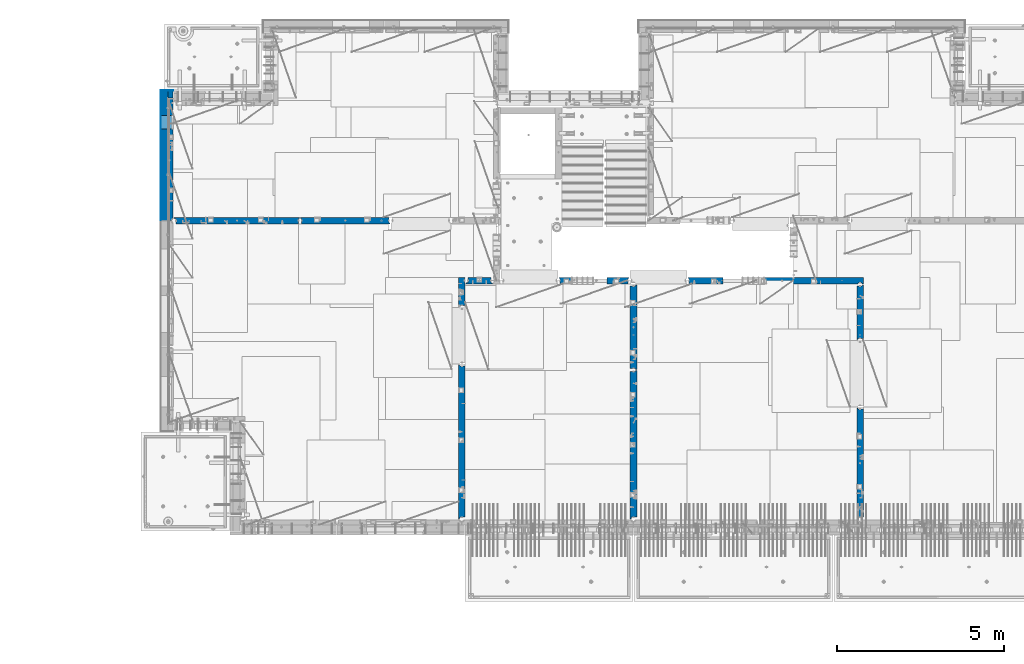
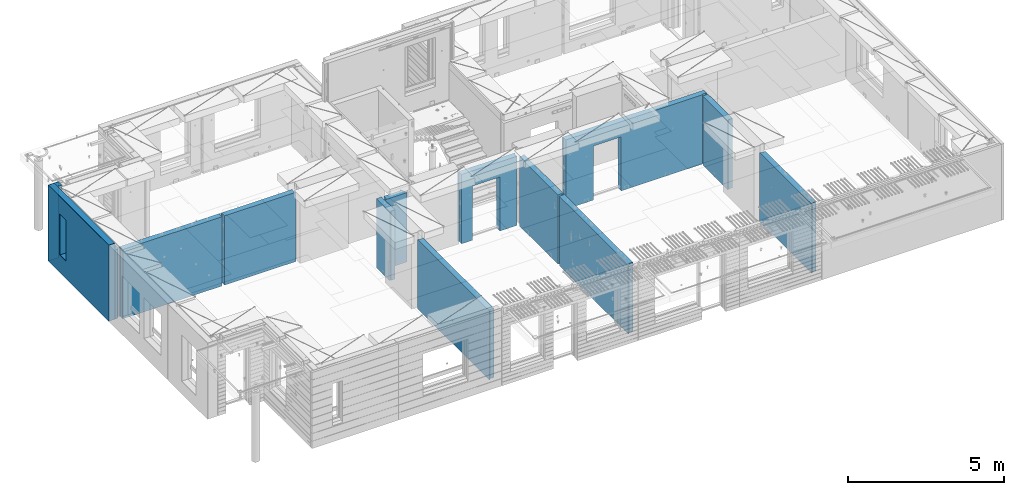
# One storey, part 226 of 341: 16 walls, 12 elements without a shape of their own.
"""IFC2X3 building model written with IfcOpenShell, lengths in millimetres."""

from ifc_helpers import new_model, si_unit, frame, origin_with_axes, place, context, subcontext, project, spatial, faceted_brep, material, type_object, element, aggregate, save


model = new_model("IFC2X3")

# Units and contexts
model_context = context("Model", 3, precision=1e-05, world=origin_with_axes())
body_context = subcontext(model_context, "Body", "Model", "MODEL_VIEW")
ifc_project = project(units=[si_unit("LENGTHUNIT", "METRE", prefix="MILLI"), si_unit("AREAUNIT", "SQUARE_METRE"), si_unit("VOLUMEUNIT", "CUBIC_METRE"), si_unit("MASSUNIT", "GRAM", prefix="KILO"), si_unit("TIMEUNIT", "SECOND"), si_unit("PLANEANGLEUNIT", "RADIAN"), si_unit("SOLIDANGLEUNIT", "STERADIAN"), si_unit("THERMODYNAMICTEMPERATUREUNIT", "DEGREE_CELSIUS"), si_unit("LUMINOUSINTENSITYUNIT", "LUMEN")], contexts=[model_context])

# Site, building, storey
site_placement = place(None, origin_with_axes())
site = spatial("IfcSite", under=ifc_project, at=site_placement, CompositionType="ELEMENT")
building_placement = place(site_placement, origin_with_axes())
building = spatial("IfcBuilding", under=site, at=building_placement, CompositionType="ELEMENT")
storey_placement = place(building_placement, origin_with_axes())
storey = spatial("IfcBuildingStorey", under=building, at=storey_placement, Name="5", CompositionType="ELEMENT", Elevation=0.0)

# Assembly, wall
assembly_1_placement = place(storey_placement, origin_with_axes())
assembly_1 = element("IfcElementAssembly", 1, at=assembly_1_placement, inside=storey, AssemblyPlace="NOTDEFINED", PredefinedType="REINFORCEMENT_UNIT")
ifc_material_1 = material(Name="CONCRETE/C25/30")
wall_type_1 = type_object("IfcWallType", PredefinedType="NOTDEFINED")
wall_1_placement = place(assembly_1_placement, frame((28610.0, 13387.9996249472, 95112.5), z_axis=(0.0, 0.0, 1.0), x_axis=(0.0, 1.0, 0.0)))
wall_1 = element("IfcWall", 2, at=wall_1_placement, type_object=wall_type_1, material=ifc_material_1, context=body_context, shape_type="Brep", body=[
    faceted_brep([(30.9999999999982, 70.0000000000073, 1357.5), (30.9999999999982, 70.0000000000073, -1357.5), (60.9999999999982, 57.0000000000036, -1357.5), (60.9999999999982, 57.0000000000036, 1357.5), (60.9999999999982, -100.0, 1357.5), (60.9999999999982, -100.0, -1357.5), (30.9999999999982, 100.0, -1357.5), (30.9999999999982, 100.0, 1357.5), (1631.00037505278, 100.0, 1357.5), (1631.00037505278, 100.0, -1357.5), (1631.00037505278, -56.9999999999964, 1357.5), (1631.00037505278, -56.9999999999964, -1357.5), (1661.00037505278, -70.0, 1357.5), (1661.00037505278, -70.0, -1357.5), (1661.00037505278, -100.0, 1357.5), (1661.00037505278, -100.0, -1357.5)], [[[0, 1, 2, 3]], [[4, 3, 2, 5]], [[6, 7, 8, 9]], [[10, 11, 9, 8]], [[12, 13, 11, 10]], [[14, 15, 13, 12]], [[15, 14, 4, 5]], [[1, 6, 9, 11, 13, 15, 5, 2]], [[7, 6, 1, 0]], [[14, 12, 10, 8, 7, 0, 3, 4]]]),
])
aggregate(assembly_1, [wall_1])

assembly_2_placement = place(storey_placement, origin_with_axes())
assembly_2 = element("IfcElementAssembly", 3, at=assembly_2_placement, inside=storey, AssemblyPlace="NOTDEFINED", PredefinedType="REINFORCEMENT_UNIT")
wall_2_placement = place(assembly_2_placement, frame((28610.0, 8000.0, 95112.5), z_axis=(0.0, 0.0, 1.0), x_axis=(0.0, 1.0, 0.0)))
wall_2 = element("IfcWall", 4, at=wall_2_placement, type_object=wall_type_1, material=ifc_material_1, context=body_context, shape_type="Brep", body=[
    faceted_brep([(30.0000000000009, 70.0, 1357.5), (30.0, 70.0, -1357.5), (80.0, 57.0, -1357.5), (79.99999955967, 57.0000001052285, 1357.5), (79.9999996695051, -100.0, 1357.5), (80.0, -100.0, -1357.5), (30.0, 100.0, -1357.5), (30.0000000000009, 100.0, 1357.5), (3360.0, 100.0, 1357.5), (3360.0, 100.0, -1357.5), (3360.0, 70.0000000000073, 1357.5), (3360.0, 70.0000000000073, -1357.5), (3330.0, 57.0000000000036, 1357.5), (3330.0, 57.0000000000036, -1357.5), (3330.0, -100.0, 1357.5), (3330.0, -100.0, -1357.5)], [[[0, 1, 2, 3]], [[4, 3, 2, 5]], [[6, 7, 8, 9]], [[9, 8, 10, 11]], [[12, 13, 11, 10]], [[14, 15, 13, 12]], [[15, 14, 4, 5]], [[1, 6, 9, 11, 13, 15, 5, 2]], [[7, 6, 1, 0]], [[14, 12, 10, 8, 7, 0, 3, 4]]]),
])
aggregate(assembly_2, [wall_2])

assembly_3_placement = place(storey_placement, origin_with_axes())
assembly_3 = element("IfcElementAssembly", 5, at=assembly_3_placement, inside=storey, AssemblyPlace="NOTDEFINED", PredefinedType="REINFORCEMENT_UNIT")
wall_3_placement = place(assembly_3_placement, frame((23410.0002919986, 15180.0, 95112.5), z_axis=(0.0, 0.0, 1.0), x_axis=(1.0, 0.0, 0.0)))
wall_3 = element("IfcWall", 6, at=wall_3_placement, type_object=wall_type_1, material=ifc_material_1, context=body_context, shape_type="Brep", body=[
    faceted_brep([(3134.99885559082, 100.0, 762.5), (3147.99885559082, 80.0, 762.5), (3251.99885559082, 80.0, 762.5), (3264.99885559082, 100.0, 762.5), (3147.99885559082, 80.0, 1357.5), (3134.99885559082, 100.0, 1357.5), (3251.99885559082, 80.0, 1357.5), (3264.99885559082, 100.0, 1357.5), (5299.99970800144, -100.0, -1357.5), (5299.99970800144, -100.0, 1357.5), (5264.99970800144, -100.0, 1357.5), (5264.99970800144, -100.0, -1357.5), (5251.99970800144, -70.0, 1357.5), (5251.99970800144, -70.0, -1357.5), (5147.99970800144, -70.0, 1357.5), (5147.99970800144, -70.0, -1357.5), (5134.99970800144, -100.0, 1357.5), (5134.99970800144, -100.0, -1357.5), (59.9988535092562, -100.0, 1357.5), (59.9988535092562, -100.0, -1357.5), (1090.00039464695, -100.0, -1357.5), (1090.00039464695, -100.0, 762.5), (2110.00039464695, -100.0, 762.5), (2110.00039464695, -100.0, -1357.5), (59.9988535092562, 57.0, 1357.5), (59.9988535092562, 57.0, -1357.5), (29.9988535092562, 70.0000000000018, 1357.5), (29.9988535092562, 70.0000000000018, -1357.5), (29.9988535092562, 100.0, 1357.5), (29.9988535092562, 100.0, -1357.5), (1090.00039464695, 100.0, -1357.5), (1090.00039464695, 100.0, 762.5), (2110.00039464695, 100.0, 762.5), (2110.00039464695, 100.0, -1357.5), (5299.99970800144, 100.0, -1357.5), (5299.99970800144, 100.0, 1357.5)], [[[0, 1, 2, 3]], [[4, 1, 0, 5]], [[6, 2, 1, 4]], [[7, 3, 2, 6]], [[8, 9, 10, 11]], [[10, 12, 13, 11]], [[14, 15, 13, 12]], [[16, 17, 15, 14]], [[17, 16, 18, 19, 20, 21, 22, 23]], [[24, 25, 19, 18]], [[26, 27, 25, 24]], [[28, 29, 27, 26]], [[19, 25, 27, 29, 30, 20]], [[31, 21, 20, 30]], [[32, 22, 21, 31]], [[33, 23, 22, 32]], [[34, 8, 11, 13, 15, 17, 23, 33]], [[9, 8, 34, 35]], [[4, 5, 28, 26, 24, 18, 16, 14, 12, 10, 9, 35, 7, 6]], [[35, 34, 33, 32, 31, 30, 29, 28, 5, 0, 3, 7]]]),
])
aggregate(assembly_3, [wall_3])

assembly_4_placement = place(storey_placement, origin_with_axes())
assembly_4 = element("IfcElementAssembly", 7, at=assembly_4_placement, inside=storey, AssemblyPlace="NOTDEFINED", PredefinedType="REINFORCEMENT_UNIT")
wall_4_placement = place(assembly_4_placement, frame((21810.0, 12500.0, 95112.5), z_axis=(0.0, 0.0, 1.0), x_axis=(0.0, 1.0, 0.0)))
wall_4 = element("IfcWall", 8, at=wall_4_placement, type_object=wall_type_1, material=ifc_material_1, context=body_context, shape_type="Brep", body=[
    faceted_brep([(2519.9998239177, -57.0, 1357.5), (2519.9998239177, -57.0, -1357.5), (2519.9998239177, 100.0, -1357.5), (2519.9998239177, 100.0, 1357.5), (2549.9998239177, -70.0, 1357.5), (2549.9998239177, -70.0, -1357.5), (45.0, 100.0, 1357.5), (45.0, 100.0, -1357.5), (45.0, -57.0, -1357.5), (45.0, -57.0, 1357.5), (15.0, -70.0, 1357.5), (15.0, -70.0000000000036, -1357.5), (15.0, -100.0, -1357.5), (15.0, -100.0, 1357.5), (2549.9998239177, -100.0, -1357.5), (2549.9998239177, -100.0, 1357.5)], [[[0, 1, 2, 3]], [[4, 5, 1, 0]], [[6, 7, 8, 9]], [[10, 9, 8, 11]], [[12, 13, 10, 11]], [[13, 12, 14, 15]], [[3, 6, 9, 10, 13, 15, 4, 0]], [[7, 6, 3, 2]], [[14, 12, 11, 8, 7, 2, 1, 5]], [[15, 14, 5, 4]]]),
])
aggregate(assembly_4, [wall_4])

assembly_5_placement = place(storey_placement, origin_with_axes())
assembly_5 = element("IfcElementAssembly", 9, at=assembly_5_placement, inside=storey, AssemblyPlace="NOTDEFINED", PredefinedType="REINFORCEMENT_UNIT")
wall_5_placement = place(assembly_5_placement, frame((21810.0, 8000.0, 95112.5), z_axis=(0.0, 0.0, 1.0), x_axis=(0.0, 1.0, 0.0)))
wall_5 = element("IfcWall", 10, at=wall_5_placement, type_object=wall_type_1, material=ifc_material_1, context=body_context, shape_type="Brep", body=[
    faceted_brep([(30.0000000000009, 70.0, 1357.5), (30.0, 70.0, -1357.5), (80.0, 57.0, -1357.5), (79.99999955967, 57.0000001052285, 1357.5), (79.9999996695051, -100.0, 1357.5), (80.0, -100.0, -1357.5), (30.0, 100.0, -1357.5), (30.0000000000009, 100.0, 1357.5), (4455.0, 100.0, 1357.5), (4455.0, 100.0, -1357.5), (4455.0, -57.0, 1357.5), (4455.0, -57.0, -1357.5), (4485.0, -70.0000000000036, 1357.5), (4485.0, -70.0000000000036, -1357.5), (4485.0, -100.0, 1357.5), (4485.0, -100.0, -1357.5)], [[[0, 1, 2, 3]], [[4, 3, 2, 5]], [[6, 7, 8, 9]], [[10, 11, 9, 8]], [[12, 13, 11, 10]], [[14, 15, 13, 12]], [[15, 14, 4, 5]], [[1, 6, 9, 11, 13, 15, 5, 2]], [[7, 6, 1, 0]], [[14, 12, 10, 8, 7, 0, 3, 4]]]),
])
aggregate(assembly_5, [wall_5])

assembly_6_placement = place(storey_placement, origin_with_axes())
assembly_6 = element("IfcElementAssembly", 11, at=assembly_6_placement, inside=storey, AssemblyPlace="NOTDEFINED", PredefinedType="REINFORCEMENT_UNIT")
wall_6_placement = place(assembly_6_placement, frame((19569.9991455076, 15180.0000000001, 95112.5), z_axis=(0.0, 0.0, 1.0), x_axis=(1.0, 0.0, 0.0)))
wall_6 = element("IfcWall", 12, at=wall_6_placement, type_object=wall_type_1, material=ifc_material_1, context=body_context, shape_type="Brep", body=[
    faceted_brep([(30.0000000001819, 56.9999999999745, 1357.5), (30.0000000001819, 56.9999999999745, -1357.5), (30.0000000001819, -100.0, -1357.5), (30.0000000001819, -100.0, 1357.5), (0.0, 69.9999999999745, 1357.5), (0.0, 69.9999999999745, -1357.5), (1450.00154113788, 100.0, -1357.5), (1450.00154113788, -100.0, -1357.5), (1450.00154113788, -100.0, 762.5), (1450.00154113788, 100.0, 762.5), (430.001541137881, 100.0, 762.5), (430.001541137881, -100.0, 762.5), (430.001541137881, -100.0, -1357.5), (430.001541137881, 100.0, -1357.5), (0.0, 100.0, -1357.5), (0.0, 100.0, 1357.5), (2110.00085449221, 100.0, 1357.5), (2110.00085449221, 100.0, -1357.5), (2110.00085449272, 70.0000000037435, 1357.5), (2110.00085449221, 70.0000000037435, -1357.5), (2080.00085191853, -100.0, -1357.5), (2080.00085558004, 57.0000004585763, -1357.5), (2080.00085558004, 57.0000004585763, 1357.5), (2080.00085191853, -100.0, 1357.5)], [[[0, 1, 2, 3]], [[4, 5, 1, 0]], [[6, 7, 8, 9]], [[10, 11, 12, 13]], [[9, 8, 11, 10]], [[13, 14, 15, 16, 17, 6, 9, 10]], [[17, 16, 18, 19]], [[20, 7, 6, 17, 19, 21]], [[18, 22, 21, 19]], [[23, 20, 21, 22]], [[12, 11, 8, 7, 20, 23, 3, 2]], [[14, 13, 12, 2, 1, 5]], [[15, 14, 5, 4]], [[23, 22, 18, 16, 15, 4, 0, 3]]]),
])
aggregate(assembly_6, [wall_6])

assembly_7_placement = place(storey_placement, origin_with_axes())
assembly_7 = element("IfcElementAssembly", 13, at=assembly_7_placement, inside=storey, AssemblyPlace="NOTDEFINED", PredefinedType="REINFORCEMENT_UNIT")
wall_7_placement = place(assembly_7_placement, frame((16660.0, 8000.0, 95112.5), z_axis=(0.0, 0.0, 1.0), x_axis=(0.0, 1.0, 0.0)))
wall_7 = element("IfcWall", 14, at=wall_7_placement, type_object=wall_type_1, material=ifc_material_1, context=body_context, shape_type="Brep", body=[
    faceted_brep([(30.0000000000009, 70.0, 1357.5), (30.0, 70.0, -1357.5), (80.0, 57.0, -1357.5), (79.99999955967, 57.0000001052285, 1357.5), (79.9999996695051, -100.0, 1357.5), (80.0, -100.0, -1357.5), (30.0, 100.0, -1357.5), (30.0000000000009, 100.0, 1357.5), (4644.99239711402, 100.0, 1357.5), (4644.99239711402, 100.0, -1357.5), (4644.99653549905, 70.0145277302508, 1357.5), (4644.99653549905, 70.0145277302508, -1357.5), (4614.97833252975, 57.001718635147, 1357.5), (4614.97833252975, 57.001718635147, -1357.5), (4615.00000080787, -100.0, 1357.5), (4615.00000080787, -100.0, -1357.5)], [[[0, 1, 2, 3]], [[4, 3, 2, 5]], [[6, 7, 8, 9]], [[9, 8, 10, 11]], [[12, 13, 11, 10]], [[14, 15, 13, 12]], [[15, 14, 4, 5]], [[1, 6, 9, 11, 13, 15, 5, 2]], [[7, 6, 1, 0]], [[14, 12, 10, 8, 7, 0, 3, 4]]]),
])
aggregate(assembly_7, [wall_7])

assembly_8_placement = place(storey_placement, origin_with_axes())
assembly_8 = element("IfcElementAssembly", 15, at=assembly_8_placement, inside=storey, AssemblyPlace="NOTDEFINED", PredefinedType="REINFORCEMENT_UNIT")
wall_8_placement = place(assembly_8_placement, frame((16660.0, 14375.0001284873, 95112.5), z_axis=(0.0, 0.0, 1.0), x_axis=(0.0, 1.0, 0.0)))
wall_8 = element("IfcWall", 16, at=wall_8_placement, type_object=wall_type_1, material=ifc_material_1, context=body_context, shape_type="Brep", body=[
    faceted_brep([(59.9783637637502, 57.008280238686, -607.5), (29.9765698802239, 70.004139724977, -607.5), (29.972430061518, 100.0, -607.5), (84.972430061518, 100.0, -607.5), (84.972430061518, 50.0, -607.5), (59.9793309975266, 50.0, -607.5), (84.972430061518, 50.0, -1357.5), (84.972430061518, 100.0, -1357.5), (59.9793309975285, 50.0, -1357.5), (739.999871512746, -100.0, 1357.5), (752.999871512742, -80.0, 1357.5), (856.999871512742, -80.0, 1357.5), (869.99987151274, -100.0, 1357.5), (904.999871512742, -100.0, 1357.5), (904.999871512742, 100.0, 1357.5), (29.972430061518, 100.0, 1357.5), (29.9765698802239, 70.004139724977, 1357.5), (59.9783637637502, 57.008280238686, 1357.5), (60.0000329474624, -100.0, 1357.5), (739.999871512746, -100.0, -1357.5), (60.0000329474624, -100.0, -1357.5), (752.999871512742, -80.0, -1357.5), (856.999871512742, -80.0, -1357.5), (869.99987151274, -100.0, -1357.5), (904.999871512742, -100.0, -1357.5), (904.999871512742, 100.0, -1357.5)], [[[0, 1, 2, 3, 4, 5]], [[6, 4, 3, 7]], [[8, 5, 4, 6]], [[9, 10, 11, 12, 13, 14, 15, 16, 17, 18]], [[19, 9, 18, 20]], [[9, 19, 21, 10]], [[10, 21, 22, 11]], [[12, 11, 22, 23]], [[24, 13, 12, 23]], [[13, 24, 25, 14]], [[15, 14, 25, 7, 3, 2]], [[16, 15, 2, 1]], [[17, 16, 1, 0]], [[20, 18, 17, 0, 5, 8]], [[25, 24, 23, 22, 21, 19, 20, 8, 6, 7]]]),
])
aggregate(assembly_8, [wall_8])

assembly_9_placement = place(storey_placement, origin_with_axes())
assembly_9 = element("IfcElementAssembly", 17, at=assembly_9_placement, inside=storey, AssemblyPlace="NOTDEFINED", PredefinedType="REINFORCEMENT_UNIT")
wall_9_placement = place(assembly_9_placement, frame((16790.0, 15180.0, 95112.5), z_axis=(0.0, 0.0, 1.0), x_axis=(1.0, 0.0, 0.0)))
wall_9 = element("IfcWall", 18, at=wall_9_placement, type_object=wall_type_1, material=ifc_material_1, context=body_context, shape_type="Brep", body=[
    faceted_brep([(740.0, 100.0, 1357.5), (740.0, -57.0, 1357.5), (740.0, -57.0, -1357.5), (740.0, 100.0, -1357.5), (790.0, -70.0, 1357.5), (790.0, -69.9999999999982, -1357.5), (50.0, 100.0, 1357.5), (50.0, 100.0, -1357.5), (50.0, -48.3299999999999, -1357.5), (50.0, -48.3299999999999, 1357.5), (0.0, -69.996666666666, -1357.5), (0.0, -69.996666666666, 1357.5), (0.0, -100.0, -1357.5), (0.0, -100.0, 1357.5), (790.0, -100.0, -1357.5), (790.0, -100.0, 1357.5)], [[[0, 1, 2, 3]], [[4, 5, 2, 1]], [[6, 7, 8, 9]], [[9, 8, 10, 11]], [[12, 13, 11, 10]], [[13, 12, 14, 15]], [[1, 0, 6, 9, 11, 13, 15, 4]], [[7, 6, 0, 3]], [[14, 12, 10, 8, 7, 3, 2, 5]], [[15, 14, 5, 4]]]),
])
aggregate(assembly_9, [wall_9])

assembly_10_placement = place(storey_placement, origin_with_axes())
assembly_10 = element("IfcElementAssembly", 19, at=assembly_10_placement, inside=storey, AssemblyPlace="NOTDEFINED", PredefinedType="REINFORCEMENT_UNIT")
wall_10_placement = place(assembly_10_placement, frame((11795.0, 16980.0, 95112.5), z_axis=(0.0, 0.0, 1.0), x_axis=(1.0, 0.0, 0.0)))
wall_10 = element("IfcWall", 20, at=wall_10_placement, type_object=wall_type_1, material=ifc_material_1, context=body_context, shape_type="Brep", body=[
    faceted_brep([(2680.0, 100.0, 1357.5), (2680.0, -57.0, 1357.5), (2680.0, -57.0, -1357.50000000001), (2680.0, 100.0, -1357.5), (2705.0, -67.8333333333321, 1357.5), (2705.0, -67.8333333333321, -1357.5), (25.0, 100.0, 1357.5), (25.0, 100.0, -1357.5), (25.0, 70.0000000000036, -1357.5), (25.0, 70.0000000000036, 1357.5), (55.0, 57.0, -1357.5), (55.0, 57.0, 1357.5), (55.0, -100.0, -1357.5), (55.0, -100.0, 1357.5), (2705.0, -100.0, -1357.5), (2705.0, -100.0, 1357.5)], [[[0, 1, 2, 3]], [[4, 5, 2, 1]], [[6, 7, 8, 9]], [[9, 8, 10, 11]], [[11, 10, 12, 13]], [[14, 15, 13, 12]], [[0, 6, 9, 11, 13, 15, 4, 1]], [[7, 6, 0, 3]], [[14, 12, 10, 8, 7, 3, 2, 5]], [[15, 14, 5, 4]]]),
])
aggregate(assembly_10, [wall_10])

assembly_11_placement = place(storey_placement, origin_with_axes())
assembly_11 = element("IfcElementAssembly", 21, at=assembly_11_placement, inside=storey, AssemblyPlace="NOTDEFINED", PredefinedType="REINFORCEMENT_UNIT")
wall_11_placement = place(assembly_11_placement, frame((8000.0, 16980.0, 95112.5), z_axis=(0.0, 0.0, 1.0), x_axis=(1.0, 0.0, 0.0)))
wall_11 = element("IfcWall", 22, at=wall_11_placement, type_object=wall_type_1, material=ifc_material_1, context=body_context, shape_type="Brep", body=[
    faceted_brep([(80.0, 52.0, 1357.5), (80.0, 52.0, -1357.5), (80.0, -100.0, -1357.5), (79.9999996695051, -100.0, 1357.5), (30.0000022791291, 65.0, 1357.5), (30.0000022791291, 65.0, -1357.5), (30.0, 100.0, -1357.5), (30.0000000000009, 100.0, 1357.5), (3790.0, 100.0, 1357.5), (3790.0, 100.0, -1357.5), (3790.0, 70.0000000000036, 1357.5), (3790.0, 70.0000000000036, -1357.5), (3760.0, 57.0, 1357.5), (3760.0, 57.0, -1357.5), (3760.0, -100.0, 1357.5), (3760.0, -100.0, -1357.5)], [[[0, 1, 2, 3]], [[4, 5, 1, 0]], [[6, 7, 8, 9]], [[9, 8, 10, 11]], [[10, 12, 13, 11]], [[14, 15, 13, 12]], [[15, 14, 3, 2]], [[6, 9, 11, 13, 15, 2, 1, 5]], [[7, 6, 5, 4]], [[14, 12, 10, 8, 7, 4, 0, 3]]]),
])
aggregate(assembly_11, [wall_11])

# Assembly, walls
assembly_12_placement = place(storey_placement, origin_with_axes())
assembly_12 = element("IfcElementAssembly", 23, at=assembly_12_placement, inside=storey, AssemblyPlace="NOTDEFINED", PredefinedType="REINFORCEMENT_UNIT")
ifc_material_2 = material()
wall_type_2 = type_object("IfcWallType", PredefinedType="NOTDEFINED")
wall_12_placement = place(assembly_12_placement, frame((7850.0, 20764.9951872276, 95247.5), z_axis=(0.0, 0.0, 1.0), x_axis=(1.0, 0.0, 0.0)))
wall_12 = element("IfcWall", 24, at=wall_12_placement, type_object=wall_type_2, material=ifc_material_2, context=body_context, shape_type="Brep", body=[
    faceted_brep([(0.0, 110.0, -1492.5), (0.0, 110.0, 1492.5), (150.0, 110.0, 1492.5), (150.0, 110.0, -1492.5), (0.0, -110.0, 1492.5), (150.0, -110.0, 1492.5), (0.0, -110.0, -1492.5), (150.0, -110.0, -1492.5)], [[[0, 1, 2, 3]], [[1, 4, 5, 2]], [[4, 6, 7, 5]], [[6, 0, 3, 7]], [[5, 7, 3, 2]], [[6, 4, 1, 0]]]),
])
wall_13_placement = place(assembly_12_placement, frame((7740.0, 16980.0, 95247.5), z_axis=(0.0, 0.0, 1.0), x_axis=(0.0, 1.0, 0.0)))
wall_13 = element("IfcWall", 25, at=wall_13_placement, type_object=wall_type_2, material=ifc_material_2, context=body_context, shape_type="Brep", body=[
    faceted_brep([(5.0, -110.0, 1492.5), (5.0, -110.0, -1492.5), (3894.99518722756, -110.0, -1492.5), (3894.99518722756, -110.0, 1492.5), (2745.00189658477, -110.0, -802.5), (2745.00189658477, -110.0, 807.5), (3155.00189658477, -110.0, 807.5), (3155.00189658477, -110.0, -802.5), (5.0, 110.0, 1492.5), (3894.99518722756, 110.0, 1492.5), (5.0, 110.0, -1492.5), (3894.99518722756, 110.0, -1492.5), (2745.00189658477, 110.0, -802.5), (3155.00189658477, 110.0, -802.5), (3155.00189658477, 110.0, 807.5), (2745.00189658477, 110.0, 807.5)], [[[0, 1, 2, 3], [4, 5, 6, 7]], [[8, 0, 3, 9]], [[1, 0, 8, 10]], [[1, 10, 11, 2]], [[3, 2, 11, 9]], [[10, 8, 9, 11], [12, 13, 14, 15]], [[6, 14, 13, 7]], [[5, 15, 14, 6]], [[4, 12, 15, 5]], [[7, 13, 12, 4]]]),
])
wall_type_3 = type_object("IfcWallType", PredefinedType="NOTDEFINED")
wall_14_placement = place(assembly_12_placement, frame((7925.0, 16980.0, 95112.5), z_axis=(0.0, 0.0, 1.0), x_axis=(0.0, 1.0, 0.0)))
wall_14 = element("IfcWall", 26, at=wall_14_placement, type_object=wall_type_3, material=ifc_material_1, context=body_context, shape_type="Brep", body=[
    faceted_brep([(3155.00189658477, -74.9999998692319, -667.5), (3155.00189658477, 75.0, -667.5), (2745.00189658477, 75.0, -667.5), (2745.00189658477, -74.9999999986567, -667.5), (2745.00189658477, 75.0, 942.5), (2745.00189658477, -75.000000709987, 942.5), (3155.00189658477, 75.0, 942.5), (3155.00189658477, -75.0000005805623, 942.5), (3674.99518722756, -75.0, -1357.5), (3674.99518722756, -75.0, 1357.5), (3564.99519001209, -75.0000022791282, 1357.5), (3564.99519001209, -75.0, -1357.5), (3674.99518722756, 75.0, 1357.5), (5.0, 75.0, 1357.5), (5.0, -15.0000022791291, 1357.5), (65.0, -75.0, 1357.5), (3484.99518722756, -75.0000001199542, 1357.5), (3497.99518763813, -54.9999993903657, 1357.5), (3551.99518754267, -54.9999994175314, 1357.5), (5.0, 75.0, -1357.5), (5.0, -15.0000022791291, -1357.5), (65.0, -75.0, -1357.5), (3484.99518722756, -75.0, -1357.5), (3497.99518763813, -54.9999993903657, -1357.5), (3551.99518754267, -54.9999994175314, -1357.5), (3674.99518722756, 75.0, -1357.5)], [[[0, 1, 2, 3]], [[3, 2, 4, 5]], [[5, 4, 6, 7]], [[7, 6, 1, 0]], [[8, 9, 10, 11]], [[9, 12, 13, 14, 15, 16, 17, 18, 10]], [[13, 19, 20, 14]], [[15, 14, 20, 21]], [[15, 21, 22, 16], [3, 5, 7, 0]], [[16, 22, 23, 17]], [[17, 23, 24, 18]], [[10, 18, 24, 11]], [[23, 22, 21, 20, 19, 25, 8, 11, 24]], [[9, 8, 25, 12]], [[19, 13, 12, 25], [2, 1, 6, 4]]]),
])
ifc_material_3 = material(Name="CONCRETE/C30/37")
wall_type_4 = type_object("IfcWallType", PredefinedType="NOTDEFINED")
wall_15_placement = place(assembly_12_placement, frame((7630.0, 20879.9952125549, 95247.5), z_axis=(0.0, 0.0, 1.0), x_axis=(1.0, 0.0, 0.0)))
wall_15 = element("IfcWall", 27, at=wall_15_placement, type_object=wall_type_4, material=ifc_material_3, context=body_context, shape_type="Brep", body=[
    faceted_brep([(0.0, 5.0, -1492.5), (0.0, 5.0, 1492.5), (370.0, 5.0, 1492.5), (370.0, 5.0, -1492.5), (0.0, -5.0, 1492.5), (370.0, -5.0, 1492.5), (0.0, -5.0, -1492.5), (370.0, -5.0, -1492.5)], [[[0, 1, 2, 3]], [[1, 4, 5, 2]], [[4, 6, 7, 5]], [[6, 0, 3, 7]], [[5, 7, 3, 2]], [[6, 4, 1, 0]]]),
])
wall_16_placement = place(assembly_12_placement, frame((7625.0, 16980.0, 95247.5), z_axis=(0.0, 0.0, 1.0), x_axis=(0.0, 1.0, 0.0)))
wall_16 = element("IfcWall", 28, at=wall_16_placement, type_object=wall_type_4, material=ifc_material_3, context=body_context, shape_type="Brep", body=[
    faceted_brep([(5.0, -5.0, 1492.5), (5.0, -5.0, -1492.5), (3904.99518722756, -5.0, -1492.5), (3904.99518722756, -5.0, 1492.5), (2745.00189658477, -5.0, -802.5), (2745.00189658477, -5.0, 807.5), (3155.00189658477, -5.0, 807.5), (3155.00189658477, -5.0, -802.5), (5.0, 5.0, 1492.5), (3904.99518722756, 5.0, 1492.5), (5.0, 5.0, -1492.5), (3904.99518722756, 5.0, -1492.5), (2745.00189658477, 5.0, -802.5), (3155.00189658477, 5.0, -802.5), (3155.00189658477, 5.0, 807.5), (2745.00189658477, 5.0, 807.5)], [[[0, 1, 2, 3], [4, 5, 6, 7]], [[8, 0, 3, 9]], [[1, 0, 8, 10]], [[1, 10, 11, 2]], [[3, 2, 11, 9]], [[10, 8, 9, 11], [12, 13, 14, 15]], [[6, 14, 13, 7]], [[5, 15, 14, 6]], [[4, 12, 15, 5]], [[7, 13, 12, 4]]]),
])
aggregate(assembly_12, [wall_12, wall_15, wall_13, wall_16, wall_14])

save(model, "model.ifc")
